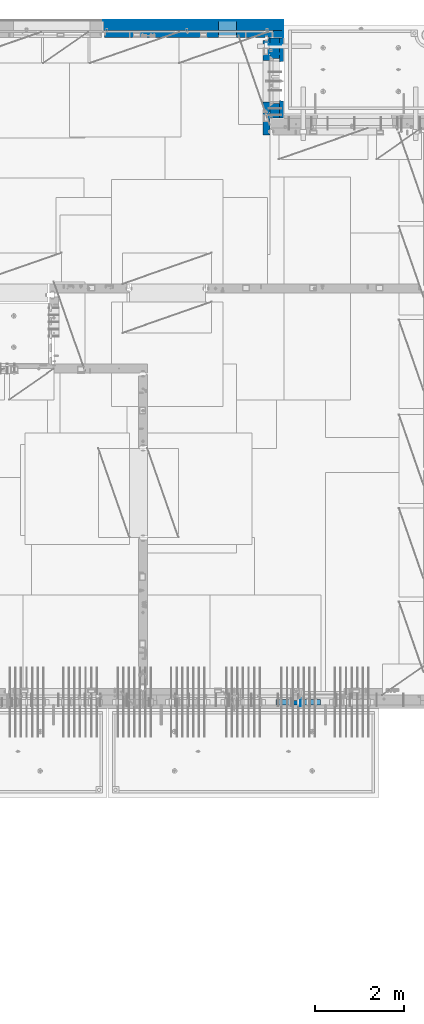
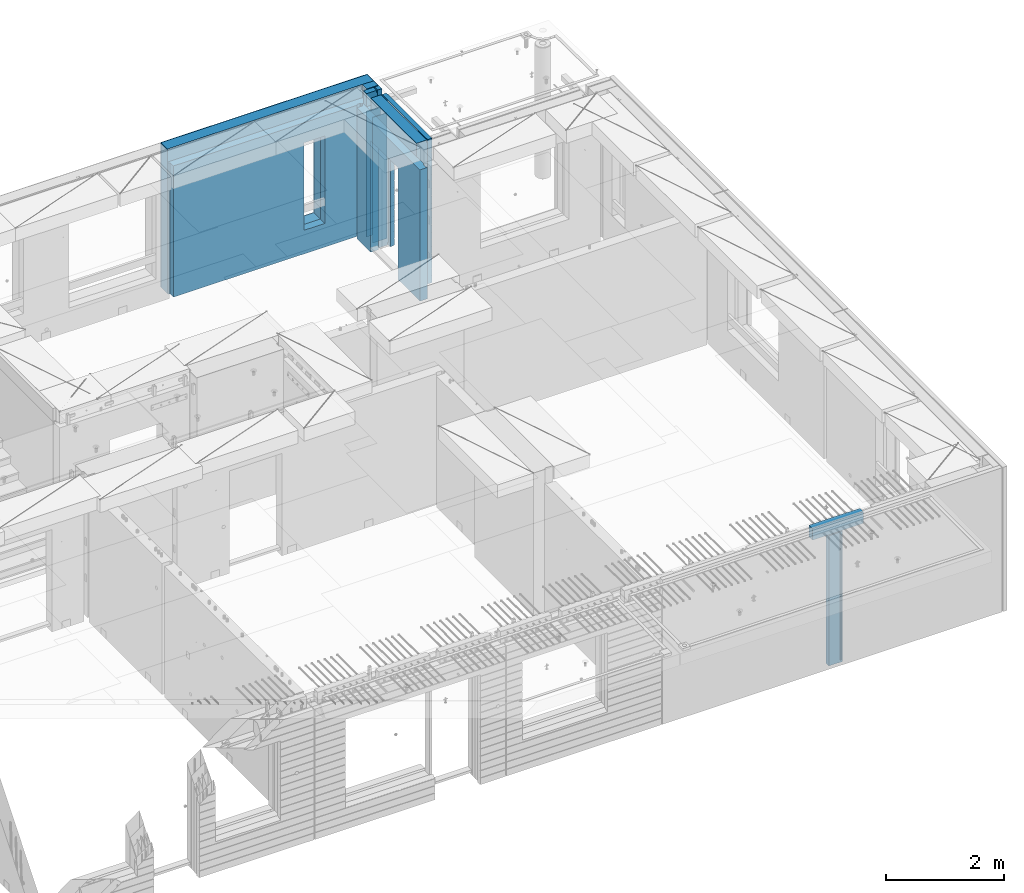
# One storey, part 241 of 350: 13 walls, 6 elements without a shape of their own.
"""IFC2X3 building model written with IfcOpenShell, lengths in millimetres."""

from ifc_helpers import new_model, si_unit, frame, origin_with_axes, place, context, subcontext, project, spatial, faceted_brep, material, type_object, element, aggregate, save


model = new_model("IFC2X3")

# Units and contexts
model_context = context("Model", 3, precision=1e-05, world=origin_with_axes())
body_context = subcontext(model_context, "Body", "Model", "MODEL_VIEW")
ifc_project = project(units=[si_unit("LENGTHUNIT", "METRE", prefix="MILLI"), si_unit("AREAUNIT", "SQUARE_METRE"), si_unit("VOLUMEUNIT", "CUBIC_METRE"), si_unit("MASSUNIT", "GRAM", prefix="KILO"), si_unit("TIMEUNIT", "SECOND"), si_unit("PLANEANGLEUNIT", "RADIAN"), si_unit("SOLIDANGLEUNIT", "STERADIAN"), si_unit("THERMODYNAMICTEMPERATUREUNIT", "DEGREE_CELSIUS"), si_unit("LUMINOUSINTENSITYUNIT", "LUMEN")], contexts=[model_context])

# Site, building, storey
site_placement = place(None, origin_with_axes())
site = spatial("IfcSite", under=ifc_project, at=site_placement, CompositionType="ELEMENT")
building_placement = place(site_placement, origin_with_axes())
building = spatial("IfcBuilding", under=site, at=building_placement, CompositionType="ELEMENT")
storey_placement = place(building_placement, origin_with_axes())
storey = spatial("IfcBuildingStorey", under=building, at=storey_placement, Name="2", CompositionType="ELEMENT", Elevation=0.0)

# Assembly, wall
assembly_1_placement = place(storey_placement, origin_with_axes())
assembly_1 = element("IfcElementAssembly", 1, at=assembly_1_placement, inside=storey, Name="Steel Assembly", AssemblyPlace="NOTDEFINED", PredefinedType="NOTDEFINED")
ifc_material_1 = material(Name="Undefined")
wall_type_1 = type_object("IfcWallType", PredefinedType="NOTDEFINED")
wall_1_placement = place(assembly_1_placement, frame((32144.9998946285, 7780.0, 86115.0), z_axis=(0.0, 0.0, 1.0), x_axis=(0.0, -1.0, 0.0)))
wall_1 = element("IfcWall", 2, at=wall_1_placement, type_object=wall_type_1, material=ifc_material_1, Name="(PD)", context=body_context, shape_type="Brep", body=[
    faceted_brep([(0.0, 5.0, -1300.0), (0.0, 5.0, 1300.0), (180.0, 5.0, 1300.0), (180.0, 5.0, -1300.0), (0.0, -5.0, 1300.0), (180.0, -5.0, 1300.0), (0.0, -5.0, -1300.0), (180.0, -5.0, -1300.0)], [[[0, 1, 2, 3]], [[1, 4, 5, 2]], [[4, 6, 7, 5]], [[6, 0, 3, 7]], [[5, 7, 3, 2]], [[6, 4, 1, 0]]]),
])
aggregate(assembly_1, [wall_1])

# Assembly, walls
assembly_2_placement = place(storey_placement, origin_with_axes())
assembly_2 = element("IfcElementAssembly", 3, at=assembly_2_placement, inside=storey, AssemblyPlace="NOTDEFINED", PredefinedType="REINFORCEMENT_UNIT")
wall_2_placement = place(assembly_2_placement, frame((31429.9951872276, 22245.0, 86115.0), z_axis=(0.0, 0.0, 1.0), x_axis=(1.0, 0.0, 0.0)))
wall_2 = element("IfcWall", 4, at=wall_2_placement, type_object=wall_type_1, material=ifc_material_1, Name="(PD)", context=body_context, shape_type="Brep", body=[
    faceted_brep([(0.0, 5.0, -1300.0), (0.0, 5.0, 1300.0), (280.0, 5.0, 1300.0), (280.0, 5.0, -1300.0), (0.0, -5.0, 1300.0), (280.0, -5.0, 1300.0), (0.0, -5.0, -1300.0), (280.0, -5.0, -1300.0)], [[[0, 1, 2, 3]], [[1, 4, 5, 2]], [[4, 6, 7, 5]], [[6, 0, 3, 7]], [[5, 7, 3, 2]], [[6, 4, 1, 0]]]),
])
wall_3_placement = place(assembly_2_placement, frame((31429.9951872276, 22454.9997558594, 86115.0), z_axis=(0.0, 0.0, 1.0), x_axis=(1.0, 0.0, 0.0)))
wall_3 = element("IfcWall", 5, at=wall_3_placement, type_object=wall_type_1, material=ifc_material_1, Name="(PD)", context=body_context, shape_type="Brep", body=[
    faceted_brep([(0.0, 5.0, -1300.0), (0.0, 5.0, 1300.0), (280.0, 5.0, 1300.0), (280.0, 5.0, -1300.0), (0.0, -5.0, 1300.0), (280.0, -5.0, 1300.0), (0.0, -5.0, -1300.0), (280.0, -5.0, -1300.0)], [[[0, 1, 2, 3]], [[1, 4, 5, 2]], [[4, 6, 7, 5]], [[6, 0, 3, 7]], [[5, 7, 3, 2]], [[6, 4, 1, 0]]]),
])

# Assemblies, wall
assembly_3_placement = place(storey_placement, origin_with_axes())
assembly_3 = element("IfcElementAssembly", 6, at=assembly_3_placement, inside=storey, AssemblyPlace="NOTDEFINED", PredefinedType="REINFORCEMENT_UNIT")
assembly_4_placement = place(assembly_3_placement, origin_with_axes())
assembly_4 = element("IfcElementAssembly", 7, at=assembly_4_placement, Name="Steel Assembly", AssemblyPlace="NOTDEFINED", PredefinedType="NOTDEFINED")
aggregate(assembly_3, [assembly_4])
ifc_material_2 = material()
wall_type_2 = type_object("IfcWallType", PredefinedType="NOTDEFINED")
wall_4_placement = place(assembly_4_placement, frame((31599.9998568133, 7690.00021946163, 87590.0), z_axis=(0.0, 0.0, 1.0), x_axis=(1.0, 0.0, 0.0)))
wall_4 = element("IfcWall", 8, at=wall_4_placement, type_object=wall_type_2, material=ifc_material_2, context=body_context, shape_type="Brep", body=[
    faceted_brep([(0.0, 60.0, -120.0), (0.0, 60.0, 120.0), (1000.0, 60.0, 120.0), (1000.0, 60.0, -120.0), (0.0, -60.0, 120.0), (1000.0, -60.0, 120.0), (0.0, -60.0, -120.0), (1000.0, -60.0, -120.0)], [[[0, 1, 2, 3]], [[1, 4, 5, 2]], [[4, 6, 7, 5]], [[6, 0, 3, 7]], [[5, 7, 3, 2]], [[6, 4, 1, 0]]]),
])
aggregate(assembly_4, [wall_4])

# Wall
ifc_material_3 = material(Name="COS5gt")
wall_type_3 = type_object("IfcWallType", PredefinedType="NOTDEFINED")
wall_5_placement = place(assembly_2_placement, frame((31569.9951872276, 22605.0, 86247.5), z_axis=(0.0, 0.0, 1.0), x_axis=(0.0, -1.0, 0.0)))
wall_5 = element("IfcWall", 9, at=wall_5_placement, type_object=wall_type_3, material=ifc_material_3, context=body_context, shape_type="Brep", body=[
    faceted_brep([(0.0, 90.0, -1492.5), (0.0, 90.0, -1442.5), (465.000109818619, 90.0, -1442.5), (465.000109818619, 90.0, -1492.5), (0.0, -110.0, -1492.5), (465.000109818619, -110.0, -1492.5), (1800.0, -110.0, 1492.5), (1800.0, 90.0, 1492.5), (255.0, 90.0, 1492.5), (255.0, -110.0, 1492.5), (1800.0, 90.0, -1442.5), (1800.0, 90.0, -1492.5), (1475.00010981862, 90.0, -1492.5), (1475.00010981862, 90.0, -1442.5), (1800.0, 110.0, -1442.5), (1475.00010981862, 110.0, -1442.5), (1800.0, 110.0, 1442.5), (1800.0, 90.0, 1442.5), (1800.0, -110.0, -1492.5), (1475.00010981862, -110.0, -1492.5), (1475.00010981862, -110.000000000004, 857.5), (1475.00010981862, 110.0, 857.5), (465.000109818619, -110.000000000004, 857.5), (465.000109818619, 110.0, 857.5), (255.0, -110.0, 1222.5), (105.0, -110.0, 1222.5), (105.0, -110.0, 1492.5), (0.0, -110.0, 1492.5), (0.0, 90.0, 1492.5), (105.0, 90.0, 1492.5), (0.0, 110.0, 1442.5), (0.0, 90.0, 1442.5), (105.0, 90.0, 1442.5), (105.0, 110.0, 1442.5), (0.0, 110.0, -1442.5), (465.000109818619, 110.0, -1442.5), (105.0, 110.0, 1222.5), (255.0, 110.0, 1222.5), (255.0, 110.0, 1442.5), (255.0, 90.0, 1442.5)], [[[0, 1, 2, 3]], [[4, 0, 3, 5]], [[6, 7, 8, 9]], [[10, 11, 12, 13]], [[14, 10, 13, 15]], [[16, 17, 7, 6, 18, 11, 10, 14]], [[11, 18, 19, 12]], [[15, 13, 12, 19, 20, 21]], [[21, 20, 22, 23]], [[19, 18, 6, 9, 24, 25, 26, 27, 4, 5, 22, 20]], [[28, 27, 26, 29]], [[30, 31, 32, 33]], [[0, 4, 27, 28, 31, 30, 34, 1]], [[1, 34, 35, 2]], [[23, 22, 5, 3, 2, 35]], [[34, 30, 33, 36, 37, 38, 16, 14, 15, 21, 23, 35]], [[17, 16, 38, 39]], [[7, 17, 39, 8]], [[38, 37, 24, 9, 8, 39]], [[36, 25, 24, 37]], [[33, 32, 29, 26, 25, 36]], [[31, 28, 29, 32]]]),
])

# Assembly, walls
assembly_5_placement = place(storey_placement, origin_with_axes())
assembly_5 = element("IfcElementAssembly", 10, at=assembly_5_placement, inside=storey, AssemblyPlace="NOTDEFINED", PredefinedType="REINFORCEMENT_UNIT")
ifc_material_4 = material()
wall_6_placement = place(assembly_5_placement, frame((31645.0, 22620.0, 86247.5), z_axis=(0.0, 0.0, 1.0), x_axis=(0.0, 1.0, 0.0)))
wall_6 = element("IfcWall", 11, at=wall_6_placement, type_object=wall_type_3, material=ifc_material_4, context=body_context, shape_type="Brep", body=[
    faceted_brep([(0.0, 110.0, -1492.5), (0.0, 110.0, 1492.5), (150.0, 110.0, 1492.5), (150.0, 110.0, -1492.5), (0.0, -110.0, 1492.5), (150.0, -110.0, 1492.5), (0.0, -110.0, -1492.5), (150.0, -110.0, -1492.5)], [[[0, 1, 2, 3]], [[1, 4, 5, 2]], [[4, 6, 7, 5]], [[6, 0, 3, 7]], [[5, 7, 3, 2]], [[6, 4, 1, 0]]]),
])
wall_7_placement = place(assembly_5_placement, frame((27720.0, 22880.0, 86247.5), z_axis=(0.0, 0.0, 1.0), x_axis=(1.0, 0.0, 0.0)))
wall_7 = element("IfcWall", 12, at=wall_7_placement, type_object=wall_type_3, material=ifc_material_4, context=body_context, shape_type="Brep", body=[
    faceted_brep([(0.0, -110.0, -1492.5), (0.0, 110.0, -1492.5), (4035.0, 110.0, -1492.5), (4035.0, -110.0, -1492.5), (0.0, -110.0, 1492.5), (0.0, 110.0, 1492.5), (4035.0, -110.0, 1492.5), (4035.0, 110.0, 1492.5), (2584.99948280293, 110.0, -1002.5), (2994.99948280293, 110.0, -1002.5), (2994.99948280293, 110.0, 807.5), (2584.99948280293, 110.0, 807.5), (2584.99948280293, -110.0, -1002.5), (2584.99948280293, -110.0, 807.5), (2994.99948280293, -110.0, 807.5), (2994.99948280293, -110.0, -1002.5)], [[[0, 1, 2, 3]], [[0, 4, 5, 1]], [[5, 4, 6, 7]], [[1, 5, 7, 2], [8, 9, 10, 11]], [[6, 3, 2, 7]], [[4, 0, 3, 6], [12, 13, 14, 15]], [[10, 14, 13, 11]], [[9, 15, 14, 10]], [[8, 12, 15, 9]], [[11, 13, 12, 8]]]),
])

# Wall
ifc_material_5 = material(Name="CONCRETE/C30/37")
wall_type_4 = type_object("IfcWallType", PredefinedType="NOTDEFINED")
wall_8_placement = place(assembly_2_placement, frame((31722.4951872276, 22605.0, 86247.5), z_axis=(0.0, 0.0, 1.0), x_axis=(0.0, -1.0, 0.0)))
wall_8 = element("IfcWall", 13, at=wall_8_placement, type_object=wall_type_4, material=ifc_material_5, context=body_context, shape_type="Brep", body=[
    faceted_brep([(0.0, 32.4999992507037, 744.999999999258), (0.0, 32.4999991127006, 755.00000040044), (526.17471776616, 32.4999991126897, 755.000000400425), (526.174717749924, 32.4999992507001, 744.999999999229), (0.0, 42.5, 742.999999944761), (524.998050995091, 42.4999995462422, 742.999999944761), (0.0, 42.5, 606.999999889245), (524.998050995091, 42.4999994639038, 606.999999889245), (3.63797880709171e-12, 32.4999991127006, 605.00000040044), (526.17471776616, 32.4999991126897, 605.000000400425), (3.63797880709171e-12, 32.4999992507037, 594.999999999258), (526.174717749924, 32.4999992507001, 594.999999999229), (0.0, 42.5, 592.999999944761), (524.998050995091, 42.4999995343132, 592.999999944761), (0.0, 42.5, 456.999999889245), (524.998050995091, 42.4999994639038, 456.999999889245), (0.0, 32.4999991127006, 455.00000040044), (526.17471776616, 32.4999991126897, 455.000000400425), (0.0, 32.4999992507037, 444.999999999258), (526.174717749924, 32.4999992507001, 444.999999999229), (0.0, 42.5, 442.999999944761), (524.998050995091, 42.4999995254038, 442.999999944761), (0.0, 42.5, 306.999999889245), (524.998050995091, 42.4999994639038, 306.999999889245), (-3.63797880709171e-12, 32.4999991127006, 305.00000040044), (526.17471776616, 32.4999991126897, 305.000000400425), (-3.63797880709171e-12, 32.4999992507037, 294.999999999258), (526.174717749924, 32.4999992507001, 294.999999999229), (0.0, 42.5, 292.999999944761), (524.998050995091, 42.499999518499, 292.999999944761), (0.0, 42.5, 156.999999889245), (524.998050995091, 42.4999994639038, 156.999999889245), (-3.63797880709171e-12, 32.4999991127006, 155.00000040044), (526.17471776616, 32.4999991126897, 155.000000400425), (-3.63797880709171e-12, 32.4999992507037, 144.999999999258), (526.174717749924, 32.4999992507001, 144.999999999229), (0.0, 42.5, 142.999999944761), (524.998050995091, 42.4999995129838, 142.999999944761), (0.0, 42.5, 6.99999988924537), (524.998050995091, 42.4999994639038, 6.99999988924537), (0.0, 32.4999991127006, 5.0000004004396), (526.17471776616, 32.4999991126897, 5.00000040042505), (0.0, 32.4999992507037, -5.00000000074215), (526.174717749924, 32.4999992507001, -5.00000000077125), (0.0, 42.5, -7.00000005523907), (524.998050995091, 42.49999950848, -7.00000005523907), (0.0, 42.5, -143.000000110755), (524.998050995091, 42.4999994639038, -143.000000110755), (3.63797880709171e-12, 32.4999991127006, -144.99999959956), (526.17471776616, 32.4999991126897, -144.999999599575), (3.63797880709171e-12, 32.4999992507037, -155.000000000742), (526.174717749924, 32.4999992507001, -155.000000000771), (0.0, 42.5, -157.000000055239), (524.998050995091, 42.4999995047365, -157.000000055239), (0.0, 42.5, -293.000000110755), (524.998050995091, 42.4999994639038, -293.000000110755), (0.0, 32.4999991127006, -294.99999959956), (526.17471776616, 32.4999991126897, -294.999999599575), (0.0, 32.4999992507037, -305.000000000742), (526.174717749924, 32.4999992507001, -305.000000000771), (0.0, 42.5, -307.000000055239), (524.998050995091, 42.4999995015714, -307.000000055239), (0.0, 42.5, -443.000000110755), (524.998050995091, 42.4999994639038, -443.000000110755), (0.0, 32.4999991127006, -444.99999959956), (526.17471776616, 32.4999991126897, -444.999999599575), (0.0, 32.4999992507037, -455.000000000742), (526.174717749924, 32.4999992507001, -455.000000000771), (0.0, 42.5, -457.000000055239), (524.998050995091, 42.4999994988648, -457.000000055239), (0.0, 42.5, -593.000000110755), (524.998050995091, 42.4999994639038, -593.000000110755), (3.63797880709171e-12, 32.4999991127006, -594.99999959956), (526.17471776616, 32.4999991126897, -594.999999599575), (3.63797880709171e-12, 32.4999992507037, -605.000000000742), (526.174717749924, 32.4999992507001, -605.000000000771), (0.0, 42.5, -607.000000055239), (524.998050995091, 42.4999994965183, -607.000000055239), (0.0, 42.5, -743.000000110755), (524.998050995091, 42.4999994639038, -743.000000110755), (0.0, 32.4999991127006, -744.99999959956), (526.17471776616, 32.4999991126897, -744.999999599575), (0.0, 32.4999992507037, -755.000000000742), (526.174717749924, 32.4999992507001, -755.000000000771), (0.0, 42.5, -757.000000055239), (524.998050995091, 42.4999994944665, -757.000000055239), (0.0, 42.5, -893.000000110755), (524.998050995091, 42.4999994639038, -893.000000110755), (0.0, 32.4999991127006, -894.99999959956), (526.17471776616, 32.4999991126897, -894.999999599575), (0.0, 32.4999992507037, -905.000000000742), (526.174717749924, 32.4999992507001, -905.000000000771), (0.0, 42.5, -907.000000055239), (524.998050995091, 42.4999994926584, -907.000000055239), (0.0, 42.5, -1043.00000011075), (524.998050995091, 42.4999994639038, -1043.00000011075), (0.0, 32.4999991127006, -1044.99999959956), (526.17471776616, 32.4999991126897, -1044.99999959957), (0.0, 32.4999992507037, -1055.00000000074), (526.174717749924, 32.4999992507001, -1055.00000000077), (0.0, 42.5, -1057.00000005524), (524.998050995091, 42.499999491054, -1057.00000005524), (0.0, 42.5, -1193.00000011075), (524.998050995091, 42.4999994639038, -1193.00000011075), (0.0, 32.4999991127006, -1194.99999959956), (526.17471776616, 32.4999991126897, -1194.99999959957), (0.0, 32.4999992507037, -1205.00000000074), (526.174717749924, 32.4999992507001, -1205.00000000077), (0.0, 42.5, -1207.00000005524), (524.998050995091, 42.499999489617, -1207.00000005524), (0.0, 42.5, -1343.00000011075), (524.998050995091, 42.4999994639038, -1343.00000011075), (0.0, 32.4999991127006, -1344.99999959956), (526.17471776616, 32.4999991126897, -1344.99999959957), (0.0, 32.4999992507037, -1355.00000000074), (526.174717749924, 32.4999992507001, -1355.00000000077), (0.0, 42.5, -1357.00000005524), (524.998050995091, 42.5, -1357.00000005524), (0.0, 42.5, -1492.5), (524.998050995091, 42.5, -1492.5), (0.0, 42.5, 1356.99999988925), (0.0, 42.5, 1492.5), (105.0, 42.5, 1492.5), (105.0, 42.499999287309, 1356.99999988925), (0.0, -42.5, 1492.5), (105.0, -42.5, 1492.5), (1800.0, 32.4999991126897, 755.000000400425), (1800.0, 32.4999992507001, 744.999999999229), (1413.82138424026, 32.4999992507001, 744.999999999229), (1413.82138422402, 32.4999991126897, 755.000000400425), (1800.0, 42.5, 742.999999944761), (1414.99805099509, 42.4999998629828, 742.999999944761), (1800.0, 42.5, 606.999999889245), (1414.99805099509, 42.4999998381209, 606.999999889245), (1800.0, 32.4999991126897, 605.000000400425), (1413.82138422402, 32.4999991126897, 605.000000400425), (1800.0, 32.4999992507001, 594.999999999229), (1413.82138424026, 32.4999992507001, 594.999999999229), (1800.0, 42.5, 592.999999944761), (1414.99805099509, 42.4999998593812, 592.999999944761), (1800.0, 42.5, 456.999999889245), (1414.99805099509, 42.4999998381209, 456.999999889245), (1800.0, 32.4999991126897, 455.000000400425), (1413.82138422402, 32.4999991126897, 455.000000400425), (1800.0, 32.4999992507001, 444.999999999229), (1413.82138424026, 32.4999992507001, 444.999999999229), (1800.0, 42.5, 442.999999944761), (1414.99805099509, 42.4999998566891, 442.999999944761), (1800.0, 42.5, 306.999999889245), (1414.99805099509, 42.4999998381209, 306.999999889245), (1800.0, 32.4999991126897, 305.000000400425), (1413.82138422402, 32.4999991126897, 305.000000400425), (1800.0, 32.4999992507001, 294.999999999229), (1413.82138424026, 32.4999992507001, 294.999999999229), (1800.0, 42.5, 292.999999944761), (1414.99805099509, 42.4999998546045, 292.999999944761), (1800.0, 42.5, 156.999999889245), (1414.99805099509, 42.4999998381209, 156.999999889245), (1800.0, 32.4999991126897, 155.000000400425), (1413.82138422402, 32.4999991126897, 155.000000400425), (1800.0, 32.4999992507001, 144.999999999229), (1413.82138424026, 32.4999992507001, 144.999999999229), (1800.0, 42.5, 142.999999944761), (1414.99805099509, 42.4999998529383, 142.999999944761), (1800.0, 42.5, 6.99999988924537), (1414.99805099509, 42.4999998381209, 6.99999988924537), (1800.0, 32.4999991126897, 5.00000040042505), (1413.82138422402, 32.4999991126897, 5.00000040042505), (1800.0, 32.4999992507001, -5.00000000077125), (1413.82138424026, 32.4999992507001, -5.00000000077125), (1800.0, 42.5, -7.00000005523907), (1414.99805099509, 42.4999998515814, -7.00000005523907), (1800.0, 42.5, -143.000000110755), (1414.99805099509, 42.4999998381209, -143.000000110755), (1800.0, 32.4999991126897, -144.999999599575), (1413.82138422402, 32.4999991126897, -144.999999599575), (1800.0, 32.4999992507001, -155.000000000771), (1413.82138424026, 32.4999992507001, -155.000000000771), (1800.0, 42.5, -157.000000055239), (1414.99805099509, 42.49999985045, -157.000000055239), (1800.0, 42.5, -293.000000110755), (1414.99805099509, 42.4999998381209, -293.000000110755), (1800.0, 32.4999991126897, -294.999999599575), (1413.82138422402, 32.4999991126897, -294.999999599575), (1800.0, 32.4999992507001, -305.000000000771), (1413.82138424026, 32.4999992507001, -305.000000000771), (1800.0, 42.5, -307.000000055239), (1414.99805099509, 42.4999998494932, -307.000000055239), (1800.0, 42.5, -443.000000110755), (1414.99805099509, 42.4999998381209, -443.000000110755), (1800.0, 32.4999991126897, -444.999999599575), (1413.82138422402, 32.4999991126897, -444.999999599575), (1800.0, 32.4999992507001, -455.000000000771), (1413.82138424026, 32.4999992507001, -455.000000000771), (1800.0, 42.5, -457.000000055239), (1414.99805099509, 42.4999998486746, -457.000000055239), (1800.0, 42.5, -593.000000110755), (1414.99805099509, 42.4999998381209, -593.000000110755), (1800.0, 32.4999991126897, -594.999999599575), (1413.82138422402, 32.4999991126897, -594.999999599575), (1800.0, 32.4999992507001, -605.000000000771), (1413.82138424026, 32.4999992507001, -605.000000000771), (1800.0, 42.5, -607.000000055239), (1414.99805099509, 42.4999998479689, -607.000000055239), (1800.0, 42.5, -743.000000110755), (1414.99805099509, 42.4999998381209, -743.000000110755), (1800.0, 32.4999991126897, -744.999999599575), (1413.82138422402, 32.4999991126897, -744.999999599575), (1800.0, 32.4999992507001, -755.000000000771), (1413.82138424026, 32.4999992507001, -755.000000000771), (1800.0, 42.5, -757.000000055239), (1414.99805099509, 42.4999998473468, -757.000000055239), (1800.0, 42.5, -893.000000110755), (1414.99805099509, 42.4999998381209, -893.000000110755), (1800.0, 32.4999991126897, -894.999999599575), (1413.82138422402, 32.4999991126897, -894.999999599575), (1800.0, 32.4999992507001, -905.000000000771), (1413.82138424026, 32.4999992507001, -905.000000000771), (1800.0, 42.5, -907.000000055239), (1414.99805099509, 42.4999998468011, -907.000000055239), (1800.0, 42.5, -1043.00000011075), (1414.99805099509, 42.4999998381209, -1043.00000011075), (1800.0, 32.4999991126897, -1044.99999959957), (1413.82138422402, 32.4999991126897, -1044.99999959957), (1800.0, 32.4999992507001, -1055.00000000077), (1413.82138424026, 32.4999992507001, -1055.00000000077), (1800.0, 42.5, -1057.00000005524), (1414.99805099509, 42.4999998463172, -1057.00000005524), (1800.0, 42.5, -1193.00000011075), (1414.99805099509, 42.4999998381209, -1193.00000011075), (1800.0, 32.4999991126897, -1194.99999959957), (1413.82138422402, 32.4999991126897, -1194.99999959957), (1800.0, 32.4999992507001, -1205.00000000077), (1413.82138424026, 32.4999992507001, -1205.00000000077), (1800.0, 42.5, -1207.00000005524), (1414.99805099509, 42.4999998458843, -1207.00000005524), (1800.0, 42.5, -1343.00000011075), (1414.99805099509, 42.4999998381209, -1343.00000011075), (1800.0, 32.4999991126897, -1344.99999959957), (1413.82138422402, 32.4999991126897, -1344.99999959957), (1800.0, 32.4999992507001, -1355.00000000077), (1413.82138424026, 32.4999992507001, -1355.00000000077), (1800.0, 42.5, -1357.00000005524), (1414.99805099509, 42.5, -1357.00000005524), (1800.0, 42.5, -1492.5), (1414.99805099509, 42.5, -1492.5), (1800.0, -42.5, -1492.5), (1404.99638432842, -42.5, -1492.5), (1414.99805099509, 42.4999998381209, 756.999999889245), (1404.99638432842, -42.5000000000036, 782.5), (1404.99638432842, -42.5000000000036, 787.502857142856), (1414.99805099509, 42.5, 782.5), (1800.0, 42.5, 756.999999889245), (0.0, 42.5, 892.999999944761), (0.0, 32.4999992507037, 894.999999999258), (1800.0, 32.4999992507001, 894.999999999229), (1800.0, 42.5, 892.999999944761), (0.0, 32.4999991127006, 905.00000040044), (1800.0, 32.4999991126897, 905.000000400425), (0.0, 42.5, 906.999999889245), (1800.0, 42.5, 906.999999889245), (0.0, 42.5, 1042.99999994476), (1800.0, 42.5, 1042.99999994476), (0.0, 32.4999992507037, 1044.99999999926), (1800.0, 32.4999992507001, 1044.99999999923), (0.0, 32.4999991127006, 1055.00000040044), (1800.0, 32.4999991126897, 1055.00000040043), (0.0, 42.5, 1056.99999988925), (1800.0, 42.5, 1056.99999988925), (0.0, 42.5, 1192.99999994476), (1800.0, 42.5, 1192.99999994476), (1800.0, -42.5, 1492.5), (1800.0, 42.5, 1492.5), (255.0, 42.5, 1492.5), (255.0, -42.5, 1492.5), (1800.0, 42.5, 1356.99999988925), (255.0, 42.499999350377, 1356.99999988925), (1800.0, 32.4999991126897, 1355.00000040043), (1800.0, 32.4999992507001, 1344.99999999923), (255.0, 32.4999992507001, 1344.99999999923), (255.0, 32.4999991126897, 1355.00000040043), (1800.0, 42.5, 1342.99999994476), (255.0, 42.4999996598308, 1342.99999994476), (105.0, 42.4999993874699, 1222.5), (105.0, -42.5, 1222.5), (255.0, -42.5, 1222.5), (255.0, 42.4999994355167, 1222.5), (1800.0, 32.4999992507001, 1194.99999999923), (1800.0, 32.4999991126897, 1205.00000040043), (1800.0, 42.5, 1206.99999988925), (0.0, 32.4999992507037, 1194.99999999926), (0.0, 32.4999991127006, 1205.00000040044), (0.0, 42.5, 1206.99999988925), (0.0, 42.5, 1342.99999994476), (105.0, 42.4999996268052, 1342.99999994476), (-3.63797880709171e-12, 32.4999992507037, 1344.99999999926), (105.0, 32.4999992507001, 1344.99999999923), (-3.63797880709171e-12, 32.4999991127006, 1355.00000040044), (105.0, 32.4999991126897, 1355.00000040043), (0.0, 42.5, 756.999999889245), (0.0, -42.5, -1492.5), (534.999717661754, -42.5, -1492.5), (534.999717661758, -42.5000000000036, 782.5), (534.999717661758, -42.5000000000036, 787.502857142856), (535.000109818619, 42.5, 782.5), (1405.00010981862, 42.5, 782.5), (524.998050995091, 42.5, 782.5), (524.998050995091, 42.4999994639038, 756.999999889245)], [[[0, 1, 2, 3]], [[4, 0, 3, 5]], [[6, 4, 5, 7]], [[8, 6, 7, 9]], [[10, 8, 9, 11]], [[12, 10, 11, 13]], [[14, 12, 13, 15]], [[16, 14, 15, 17]], [[18, 16, 17, 19]], [[20, 18, 19, 21]], [[22, 20, 21, 23]], [[24, 22, 23, 25]], [[26, 24, 25, 27]], [[28, 26, 27, 29]], [[30, 28, 29, 31]], [[32, 30, 31, 33]], [[34, 32, 33, 35]], [[36, 34, 35, 37]], [[38, 36, 37, 39]], [[40, 38, 39, 41]], [[42, 40, 41, 43]], [[44, 42, 43, 45]], [[46, 44, 45, 47]], [[48, 46, 47, 49]], [[50, 48, 49, 51]], [[52, 50, 51, 53]], [[54, 52, 53, 55]], [[56, 54, 55, 57]], [[58, 56, 57, 59]], [[60, 58, 59, 61]], [[62, 60, 61, 63]], [[64, 62, 63, 65]], [[66, 64, 65, 67]], [[68, 66, 67, 69]], [[70, 68, 69, 71]], [[72, 70, 71, 73]], [[74, 72, 73, 75]], [[76, 74, 75, 77]], [[78, 76, 77, 79]], [[80, 78, 79, 81]], [[82, 80, 81, 83]], [[84, 82, 83, 85]], [[86, 84, 85, 87]], [[88, 86, 87, 89]], [[90, 88, 89, 91]], [[92, 90, 91, 93]], [[94, 92, 93, 95]], [[96, 94, 95, 97]], [[98, 96, 97, 99]], [[100, 98, 99, 101]], [[102, 100, 101, 103]], [[104, 102, 103, 105]], [[106, 104, 105, 107]], [[108, 106, 107, 109]], [[110, 108, 109, 111]], [[112, 110, 111, 113]], [[114, 112, 113, 115]], [[116, 114, 115, 117]], [[118, 116, 117, 119]], [[120, 121, 122, 123]], [[121, 124, 125, 122]], [[126, 127, 128, 129]], [[127, 130, 131, 128]], [[130, 132, 133, 131]], [[132, 134, 135, 133]], [[134, 136, 137, 135]], [[136, 138, 139, 137]], [[138, 140, 141, 139]], [[140, 142, 143, 141]], [[142, 144, 145, 143]], [[144, 146, 147, 145]], [[146, 148, 149, 147]], [[148, 150, 151, 149]], [[150, 152, 153, 151]], [[152, 154, 155, 153]], [[154, 156, 157, 155]], [[156, 158, 159, 157]], [[158, 160, 161, 159]], [[160, 162, 163, 161]], [[162, 164, 165, 163]], [[164, 166, 167, 165]], [[166, 168, 169, 167]], [[168, 170, 171, 169]], [[170, 172, 173, 171]], [[172, 174, 175, 173]], [[174, 176, 177, 175]], [[176, 178, 179, 177]], [[178, 180, 181, 179]], [[180, 182, 183, 181]], [[182, 184, 185, 183]], [[184, 186, 187, 185]], [[186, 188, 189, 187]], [[188, 190, 191, 189]], [[190, 192, 193, 191]], [[192, 194, 195, 193]], [[194, 196, 197, 195]], [[196, 198, 199, 197]], [[198, 200, 201, 199]], [[200, 202, 203, 201]], [[202, 204, 205, 203]], [[204, 206, 207, 205]], [[206, 208, 209, 207]], [[208, 210, 211, 209]], [[210, 212, 213, 211]], [[212, 214, 215, 213]], [[214, 216, 217, 215]], [[216, 218, 219, 217]], [[218, 220, 221, 219]], [[220, 222, 223, 221]], [[222, 224, 225, 223]], [[224, 226, 227, 225]], [[226, 228, 229, 227]], [[228, 230, 231, 229]], [[230, 232, 233, 231]], [[232, 234, 235, 233]], [[234, 236, 237, 235]], [[236, 238, 239, 237]], [[238, 240, 241, 239]], [[240, 242, 243, 241]], [[242, 244, 245, 243]], [[244, 246, 247, 245]], [[248, 129, 128, 131, 133, 135, 137, 139, 141, 143, 145, 147, 149, 151, 153, 155, 157, 159, 161, 163, 165, 167, 169, 171, 173, 175, 177, 179, 181, 183, 185, 187, 189, 191, 193, 195, 197, 199, 201, 203, 205, 207, 209, 211, 213, 215, 217, 219, 221, 223, 225, 227, 229, 231, 233, 235, 237, 239, 241, 243, 245, 247, 249, 250, 251]], [[252, 126, 129, 248]], [[253, 254, 255, 256]], [[257, 258, 255, 254]], [[259, 260, 258, 257]], [[260, 259, 261, 262]], [[261, 263, 264, 262]], [[265, 266, 264, 263]], [[267, 268, 266, 265]], [[268, 267, 269, 270]], [[271, 272, 273, 274]], [[272, 275, 276, 273]], [[277, 278, 279, 280]], [[278, 281, 282, 279]], [[283, 284, 285, 286]], [[273, 276, 280, 279, 282, 286, 285, 274]], [[275, 277, 280, 276]], [[272, 271, 246, 244, 242, 240, 238, 236, 234, 232, 230, 228, 226, 224, 222, 220, 218, 216, 214, 212, 210, 208, 206, 204, 202, 200, 198, 196, 194, 192, 190, 188, 186, 184, 182, 180, 178, 176, 174, 172, 170, 168, 166, 164, 162, 160, 158, 156, 154, 152, 150, 148, 146, 144, 142, 140, 138, 136, 134, 132, 130, 127, 126, 252, 256, 255, 258, 260, 262, 264, 266, 268, 270, 287, 288, 289, 281, 278, 277, 275]], [[269, 290, 287, 270]], [[291, 288, 287, 290]], [[292, 289, 288, 291]], [[286, 282, 281, 289, 292, 293, 294, 283]], [[293, 295, 296, 294]], [[295, 297, 298, 296]], [[122, 125, 284, 283, 294, 296, 298, 123]], [[297, 120, 123, 298]], [[295, 293, 292, 291, 290, 269, 267, 265, 263, 261, 259, 257, 254, 253, 299, 1, 0, 4, 6, 8, 10, 12, 14, 16, 18, 20, 22, 24, 26, 28, 30, 32, 34, 36, 38, 40, 42, 44, 46, 48, 50, 52, 54, 56, 58, 60, 62, 64, 66, 68, 70, 72, 74, 76, 78, 80, 82, 84, 86, 88, 90, 92, 94, 96, 98, 100, 102, 104, 106, 108, 110, 112, 114, 116, 118, 300, 124, 121, 120, 297]], [[249, 247, 246, 271, 274, 285, 284, 125, 124, 300, 301, 302, 303, 250]], [[304, 305, 251, 250, 303, 306]], [[299, 253, 256, 252, 248, 251, 305, 304, 306, 307]], [[1, 299, 307, 2]], [[306, 303, 302, 301, 119, 117, 115, 113, 111, 109, 107, 105, 103, 101, 99, 97, 95, 93, 91, 89, 87, 85, 83, 81, 79, 77, 75, 73, 71, 69, 67, 65, 63, 61, 59, 57, 55, 53, 51, 49, 47, 45, 43, 41, 39, 37, 35, 33, 31, 29, 27, 25, 23, 21, 19, 17, 15, 13, 11, 9, 7, 5, 3, 2, 307]], [[300, 118, 119, 301]]]),
])

ifc_material_6 = material(Name="CONCRETE/C25/30")
wall_type_5 = type_object("IfcWallType", PredefinedType="NOTDEFINED")
wall_9_placement = place(assembly_2_placement, frame((31384.9951872276, 22620.0, 86112.5), z_axis=(0.0, 0.0, 1.0), x_axis=(0.0, -1.0, 0.0)))
wall_9 = element("IfcWall", 14, at=wall_9_placement, type_object=wall_type_5, material=ifc_material_6, context=body_context, shape_type="Brep", body=[
    faceted_brep([(2190.00481277244, -75.0, 1357.5), (2190.00481277244, -75.0, -1357.5), (2190.00481277244, 75.0, -1357.5), (2190.00481277244, 75.0, 1357.5), (2168.00481277244, 75.0, -1357.5), (2168.00481277244, 75.0, 1357.5), (2155.00481277244, 55.0, -1357.5), (2155.00481277244, 55.0, 1357.5), (2075.00481277244, 55.0, -1357.5), (2075.00481277244, 55.0, 1357.5), (2062.00481277244, 75.0, 1357.5), (2062.00481277244, 75.0, -1357.5), (15.0, 75.0, 1357.5), (15.0, 53.6666666666642, 1357.5), (65.0, 32.0, 1357.5), (65.0, -75.0, 1357.5), (15.0, 75.0, -1357.5), (15.0, 53.6666666666642, -1357.5), (65.0, 32.0, -1357.5), (65.0, -75.0, -1357.5), (1450.00010981862, -75.0, -1357.5), (520.000109818619, -75.0, -1357.5), (520.000109818619, -75.0, 952.5), (1450.00010981862, -75.0, 952.5), (1446.15395597246, 75.0, -1357.5), (1446.15395597247, 75.0, 948.653846153844), (523.846263664771, 75.0, 948.653846153844), (523.846263664771, 75.0, -1357.5)], [[[0, 1, 2, 3]], [[3, 2, 4, 5]], [[5, 4, 6, 7]], [[7, 6, 8, 9]], [[10, 9, 8, 11]], [[12, 13, 14, 15, 0, 3, 5, 7, 9, 10]], [[12, 16, 17, 13]], [[13, 17, 18, 14]], [[14, 18, 19, 15]], [[20, 1, 0, 15, 19, 21, 22, 23]], [[11, 8, 6, 4, 2, 1, 20, 24]], [[16, 12, 10, 11, 24, 25, 26, 27]], [[19, 18, 17, 16, 27, 21]], [[26, 22, 21, 27]], [[25, 23, 22, 26]], [[24, 20, 23, 25]]]),
])

aggregate(assembly_2, [wall_2, wall_3, wall_8, wall_5, wall_9])

wall_10_placement = place(assembly_5_placement, frame((27720.0, 22695.0, 86112.5), z_axis=(0.0, 0.0, 1.0), x_axis=(1.0, 0.0, 0.0)))
wall_10 = element("IfcWall", 15, at=wall_10_placement, type_object=wall_type_5, material=ifc_material_6, context=body_context, shape_type="Brep", body=[
    faceted_brep([(2584.99948280293, 75.0, 942.5), (2584.99948280293, -75.0, 942.5), (2584.99948280293, -75.0, -867.5), (2584.99948280293, 75.0, -867.5), (2994.99948280293, -75.0, -867.5), (2994.99948280293, 75.0, -867.5), (2994.99948280293, -75.0, 942.5), (2994.99948280293, 75.0, 942.5), (3815.0, -75.0, 1357.5), (3815.0, -75.0, -1357.5), (3815.0, 75.0, -1357.5), (3815.0, 75.0, 1357.5), (0.0, 75.0, -1357.5), (0.0, 75.0, 1357.5), (0.0, 45.0, -1357.5), (0.0, 45.0, 1357.5), (29.9999989126591, 32.0000004547946, -1357.5), (29.9999989126591, 32.0000004547946, 1357.5), (30.0000016637459, -75.0, -1357.5), (30.0000016637459, -75.0, 1357.5), (3624.99518722756, -75.0, 1357.5), (3637.99518722756, -55.0, 1357.5), (3691.99518722756, -55.0, 1357.5), (3704.99518722756, -75.0, 1357.5), (3704.99518722756, -75.0, -1357.5), (3637.99518722756, -55.0, -1357.5), (3624.99518722756, -75.0, -1357.5), (3691.99518722756, -55.0, -1357.5)], [[[0, 1, 2, 3]], [[3, 2, 4, 5]], [[5, 4, 6, 7]], [[7, 6, 1, 0]], [[8, 9, 10, 11]], [[12, 13, 11, 10], [3, 5, 7, 0]], [[13, 12, 14, 15]], [[15, 14, 16, 17]], [[17, 16, 18, 19]], [[8, 11, 13, 15, 17, 19, 20, 21, 22, 23]], [[9, 8, 23, 24]], [[25, 26, 18, 16, 14, 12, 10, 9, 24, 27]], [[23, 22, 27, 24]], [[21, 25, 27, 22]], [[20, 26, 25, 21]], [[19, 18, 26, 20], [2, 1, 6, 4]]]),
])

wall_type_6 = type_object("IfcWallType", PredefinedType="NOTDEFINED")
wall_11_placement = place(assembly_5_placement, frame((31760.0001313636, 22620.0, 86247.5), z_axis=(0.0, 0.0, 1.0), x_axis=(0.0, 1.0, 0.0)))
wall_11 = element("IfcWall", 16, at=wall_11_placement, type_object=wall_type_6, material=ifc_material_5, context=body_context, shape_type="Brep", body=[
    faceted_brep([(0.0, 5.0, -1492.5), (0.0, 5.0, 1492.5), (370.0, 5.0, 1492.5), (370.0, 5.0, -1492.5), (0.0, -5.0, 1492.5), (370.0, -5.0, 1492.5), (0.0, -5.0, -1492.5), (370.0, -5.0, -1492.5)], [[[0, 1, 2, 3]], [[1, 4, 5, 2]], [[4, 6, 7, 5]], [[6, 0, 3, 7]], [[5, 7, 3, 2]], [[6, 4, 1, 0]]]),
])

wall_12_placement = place(assembly_5_placement, frame((27720.0, 22995.0, 86247.5), z_axis=(0.0, 0.0, 1.0), x_axis=(1.0, 0.0, 0.0)))
wall_12 = element("IfcWall", 17, at=wall_12_placement, type_object=wall_type_6, material=ifc_material_5, context=body_context, shape_type="Brep", body=[
    faceted_brep([(0.0, -5.0, -1492.5), (0.0, 5.0, -1492.5), (4045.0, 5.0, -1492.5), (4045.0, -5.0, -1492.5), (0.0, -5.0, 1492.5), (0.0, 5.0, 1492.5), (4045.0, -5.0, 1492.5), (4045.0, 5.0, 1492.5), (2584.99948280293, 5.0, -1002.5), (2994.99948280293, 5.0, -1002.5), (2994.99948280293, 5.0, 807.5), (2584.99948280293, 5.0, 807.5), (2584.99948280293, -5.0, -1002.5), (2584.99948280293, -5.0, 807.5), (2994.99948280293, -5.0, 807.5), (2994.99948280293, -5.0, -1002.5)], [[[0, 1, 2, 3]], [[0, 4, 5, 1]], [[5, 4, 6, 7]], [[1, 5, 7, 2], [8, 9, 10, 11]], [[6, 3, 2, 7]], [[4, 0, 3, 6], [12, 13, 14, 15]], [[10, 14, 13, 11]], [[9, 15, 14, 10]], [[8, 12, 15, 9]], [[11, 13, 12, 8]]]),
])

aggregate(assembly_5, [wall_11, wall_6, wall_12, wall_7, wall_10])

# Assembly, wall
assembly_6_placement = place(storey_placement, origin_with_axes())
assembly_6 = element("IfcElementAssembly", 18, at=assembly_6_placement, inside=storey, AssemblyPlace="NOTDEFINED", PredefinedType="REINFORCEMENT_UNIT")
ifc_material_7 = material(Name="SPU")
wall_type_7 = type_object("IfcWallType", PredefinedType="NOTDEFINED")
wall_13_placement = place(assembly_6_placement, frame((32195.0000381475, 7680.0, 86102.5), z_axis=(0.0, 0.0, 1.0), x_axis=(-1.0, 3.00000001838171e-08, 0.0)))
wall_13 = element("IfcWall", 19, at=wall_13_placement, type_object=wall_type_7, material=ifc_material_7, context=body_context, shape_type="Brep", body=[
    faceted_brep([(0.0, 50.0, -1347.5), (0.0, 50.0, 1347.5), (270.001908754726, 50.0, 1347.5), (270.001908754726, 50.0, -1347.5), (0.0, -50.0, 1347.5), (270.001908754726, -50.0, 1347.5), (0.0, -50.0, -1347.5), (270.001908754726, -50.0, -1347.5)], [[[0, 1, 2, 3]], [[1, 4, 5, 2]], [[4, 6, 7, 5]], [[6, 0, 3, 7]], [[5, 7, 3, 2]], [[6, 4, 1, 0]]]),
])
aggregate(assembly_6, [wall_13])

save(model, "model.ifc")
